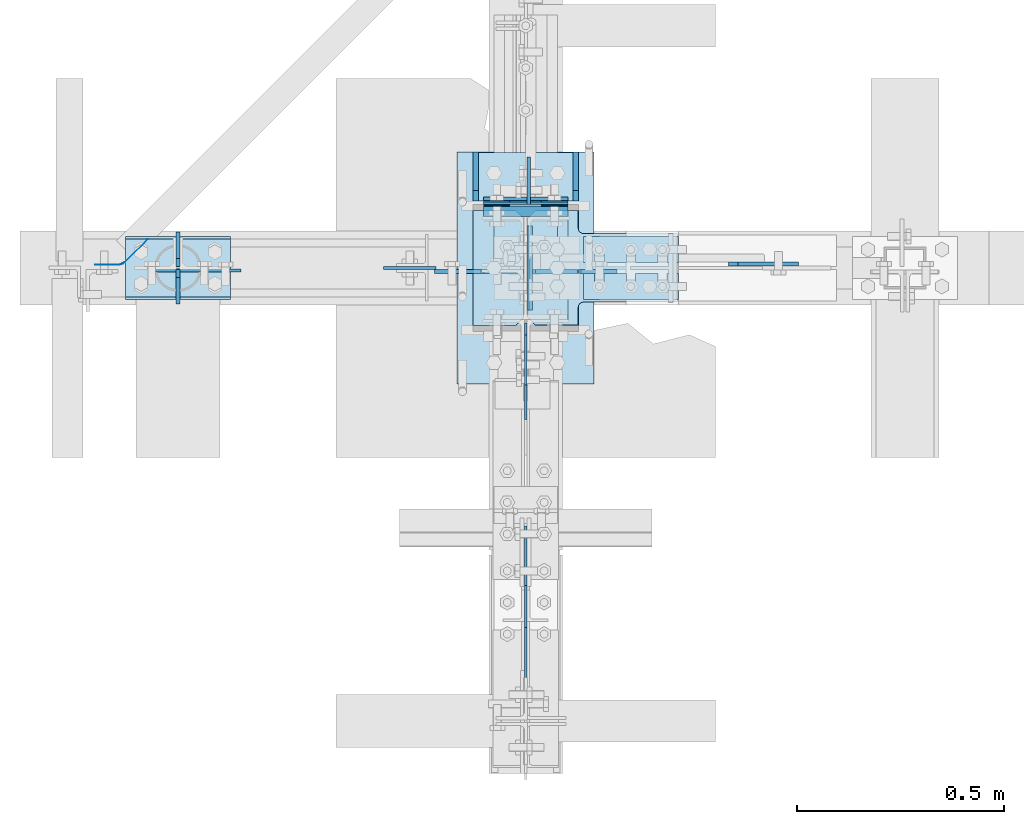
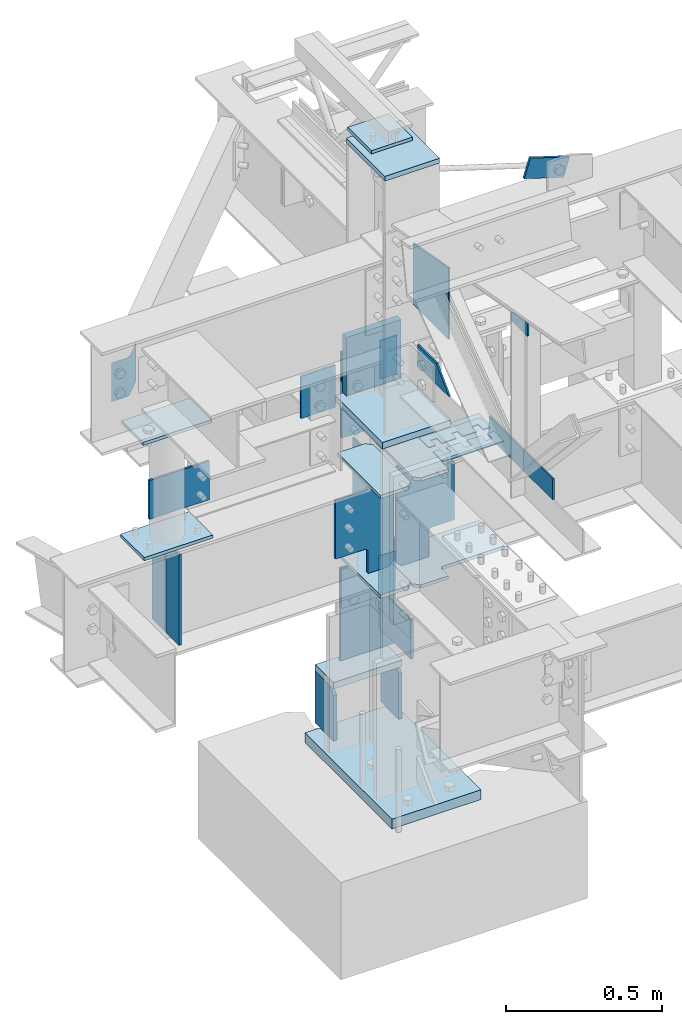
# Not in any storey, part 4 of 7: 38 plates, 16 elements without a shape of their own.
"""IFC2X3 building model written with IfcOpenShell, lengths in inches."""

import ifcopenshell
import ifcopenshell.guid

model = None  # the IFC model being written
_history = None  # IfcOwnerHistory: only IFC2X3 demands one
_inside = {}  # id of a spatial element -> (the spatial element, [elements in it])
_under = {}  # id of a project, library or spatial element -> (it, [spatial elements below it])
_declared = {}  # id of a project -> (the project, [libraries it declares])
_typed = {}  # id of a type object -> (the type object, [elements of that type])
_made_of = {}  # id of a material, layer set ... -> (it, [elements and type objects made of it])


def new_model(schema):
    """Start an empty IFC model of exactly this schema.

    Asked for "IFC4X3", IfcOpenShell would pick the latest addendum, in which some entities
    have other attributes; the version numbers below select the first issue.
    IFC2X3 requires an IfcOwnerHistory on every rooted entity: one is made here for all.
    """
    global model, _history
    if schema == "IFC4X3":
        model = ifcopenshell.file(schema_version=(4, 3, 0, 0))
    else:
        model = ifcopenshell.file(schema=schema)
    _inside.clear()
    _under.clear()
    _declared.clear()
    _typed.clear()
    _made_of.clear()
    _history = None
    if model.schema == "IFC2X3":
        org = make("IfcOrganization", Name="unknown")
        user = make(
            "IfcPersonAndOrganization",
            ThePerson=make("IfcPerson", FamilyName="unknown"),
            TheOrganization=org,
        )
        app = make(
            "IfcApplication",
            ApplicationDeveloper=org,
            Version="unknown",
            ApplicationFullName="unknown",
            ApplicationIdentifier="unknown",
        )
        _history = make(
            "IfcOwnerHistory",
            OwningUser=user,
            OwningApplication=app,
            ChangeAction="ADDED",
            CreationDate=0,
        )
    return model


def make(cls, **values):
    """One entity of the class cls with the attributes given. An attribute that is None is left unset."""
    return model.create_entity(
        cls, **{name: value for name, value in values.items() if value is not None}
    )


def entity(cls, *values):
    """Any entity or typed value of the class cls, its attributes in the order of the schema. None: left unset."""
    e = model.create_entity(cls)
    for i, value in enumerate(values):
        if value is not None:
            e[i] = value
    return e


def rooted(cls, **values):
    """An entity with a GlobalId (a new one), such as an element, a storey or a relation."""
    return make(cls, GlobalId=ifcopenshell.guid.new(), OwnerHistory=_history, **values)


def si_unit(unit_type, name, prefix=None):
    """IfcSIUnit, for example si_unit("LENGTHUNIT", "METRE", prefix="MILLI")."""
    return make("IfcSIUnit", UnitType=unit_type, Prefix=prefix, Name=name)


def converted_unit(unit_type, name, factor, base, dimensions=None, offset=None):
    """IfcConversionBasedUnit, such as the inch: factor (a typed value) times the base unit."""
    return make(
        "IfcConversionBasedUnit"
        if offset is None
        else "IfcConversionBasedUnitWithOffset",
        ConversionOffset=offset,
        Dimensions=None
        if dimensions is None
        else entity("IfcDimensionalExponents", *dimensions),
        UnitType=unit_type,
        Name=name,
        ConversionFactor=make(
            "IfcMeasureWithUnit", ValueComponent=factor, UnitComponent=base
        ),
    )


def assignment(units):
    """IfcUnitAssignment: the units of a project."""
    return None if units is None else make("IfcUnitAssignment", Units=units)


def point(xyz):
    """IfcCartesianPoint."""
    return None if xyz is None else make("IfcCartesianPoint", Coordinates=xyz)


def direction(xyz):
    """IfcDirection."""
    return None if xyz is None else make("IfcDirection", DirectionRatios=xyz)


def frame(location, z_axis=None, x_axis=None):
    """IfcAxis2Placement3D, a coordinate frame: its origin and axes. An axis left out is left unset."""
    return make(
        "IfcAxis2Placement3D",
        Location=point(location),
        Axis=direction(z_axis),
        RefDirection=direction(x_axis),
    )


def origin_with_axes():
    """The frame at (0, 0, 0) with the z axis (0, 0, 1) and the x axis (1, 0, 0) written out."""
    return frame((0.0, 0.0, 0.0), z_axis=(0.0, 0.0, 1.0), x_axis=(1.0, 0.0, 0.0))


def place(relative_to, where):
    """IfcLocalPlacement: puts the frame where relative to a parent placement (None: the world)."""
    return make(
        "IfcLocalPlacement", PlacementRelTo=relative_to, RelativePlacement=where
    )


def context(
    kind, dimensions, precision=None, world=None, true_north=None, identifier=None
):
    """IfcGeometricRepresentationContext, for example the 3D "Model" context."""
    return make(
        "IfcGeometricRepresentationContext",
        ContextIdentifier=identifier,
        ContextType=kind,
        CoordinateSpaceDimension=dimensions,
        Precision=precision,
        WorldCoordinateSystem=world,
        TrueNorth=true_north,
    )


def project(units=None, contexts=None):
    """IfcProject with its units and contexts."""
    return rooted(
        "IfcProject",
        Name="project",
        RepresentationContexts=contexts,
        UnitsInContext=assignment(units),
    )


def spatial(cls, under=None, at=None, **own):
    """A site, building, storey or space (cls), placed at a placement, below another one or the project."""
    s = rooted(cls, ObjectPlacement=at, **own)
    if under is not None:
        _under.setdefault(under.id(), (under, []))[1].append(s)
    return s


def polyline(points):
    """IfcPolyline through the points."""
    return make("IfcPolyline", Points=[point(p) for p in points])


def outline(outer, holes=None, kind="AREA"):
    """IfcArbitraryClosedProfileDef: a profile drawn as a closed curve; with holes, ...WithVoids."""
    if holes is None:
        return make("IfcArbitraryClosedProfileDef", ProfileType=kind, OuterCurve=outer)
    return make(
        "IfcArbitraryProfileDefWithVoids",
        ProfileType=kind,
        OuterCurve=outer,
        InnerCurves=holes,
    )


def extrude(swept, where, along, depth):
    """IfcExtrudedAreaSolid: the profile swept, set in the frame where, extruded along a direction by depth."""
    return make(
        "IfcExtrudedAreaSolid",
        SweptArea=swept,
        Position=where,
        ExtrudedDirection=direction(along),
        Depth=depth,
    )


def shape(context_of_items, identifier, shape_type, items):
    """IfcShapeRepresentation: the items that make up one representation, for example the "Body"."""
    return make(
        "IfcShapeRepresentation",
        ContextOfItems=context_of_items,
        RepresentationIdentifier=identifier,
        RepresentationType=shape_type,
        Items=items,
    )


def source(mapping_origin, context_of_items, identifier, shape_type, items):
    """IfcRepresentationMap: a shape defined once, which mapped items show again and again."""
    return make(
        "IfcRepresentationMap",
        MappingOrigin=mapping_origin,
        MappedRepresentation=shape(context_of_items, identifier, shape_type, items),
    )


def transform(
    local_origin,
    x_axis=None,
    y_axis=None,
    z_axis=None,
    scale=None,
    scale2=None,
    scale3=None,
    uniform=True,
):
    """IfcCartesianTransformationOperator3D, or its non-uniform kind. x_axis, y_axis, z_axis: its Axis1, 2, 3."""
    if uniform:
        return make(
            "IfcCartesianTransformationOperator3D",
            Axis1=direction(x_axis),
            Axis2=direction(y_axis),
            LocalOrigin=point(local_origin),
            Scale=scale,
            Axis3=direction(z_axis),
        )
    return make(
        "IfcCartesianTransformationOperator3DnonUniform",
        Axis1=direction(x_axis),
        Axis2=direction(y_axis),
        LocalOrigin=point(local_origin),
        Scale=scale,
        Axis3=direction(z_axis),
        Scale2=scale2,
        Scale3=scale3,
    )


def mapped(mapping_source, mapping_target):
    """IfcMappedItem: shows the shape of a source again, moved by a transform."""
    return make(
        "IfcMappedItem", MappingSource=mapping_source, MappingTarget=mapping_target
    )


def material(Name=None, Category=None):
    """IfcMaterial."""
    return make("IfcMaterial", Name=Name, Category=Category)


def made_of(thing, what):
    """Note that an element or type object is made of a material, layer set ...; save() writes the relation."""
    if what is not None:
        _made_of.setdefault(what.id(), (what, []))[1].append(thing)
    return thing


def type_object(cls, material=None, **own):
    """A type object (cls), such as IfcWallType, which elements share."""
    return made_of(rooted(cls, **own), material)


def type_shapes(of_type, sources):
    """Give a type object the sources (RepresentationMaps) that its elements show as mapped items."""
    of_type.RepresentationMaps = sources


def element(
    cls,
    number,
    at=None,
    inside=None,
    cuts=None,
    type_object=None,
    material=None,
    context=None,
    identifier="Body",
    shape_type=None,
    held_by="IfcProductDefinitionShape",
    body=None,
    shapes=None,
    **own,
):
    """One element of the class cls, such as IfcWall. Its Tag is "e" and its number.

    at: its placement. inside: the storey or other place that contains it. cuts: it is an
    opening in that element (IfcRelVoidsElement). A single representation is given by context,
    identifier, shape_type and body (its items); several are given by shapes. held_by: the class
    of the entity that holds the representations. save() writes the other relations.
    """
    e = rooted(cls, Tag="e%d" % number, ObjectPlacement=at, **own)
    if body is not None:
        shapes = [shape(context, identifier, shape_type, body)]
    if shapes is not None:
        e.Representation = make(held_by, Representations=shapes)
    if inside is not None:
        _inside.setdefault(inside.id(), (inside, []))[1].append(e)
    if cuts is not None:
        rooted(
            "IfcRelVoidsElement", RelatingBuildingElement=cuts, RelatedOpeningElement=e
        )
    if type_object is not None:
        _typed.setdefault(type_object.id(), (type_object, []))[1].append(e)
    return made_of(e, material)


def aggregate(whole, parts):
    """IfcRelAggregates: a whole, such as a stair, and the parts it consists of."""
    return rooted("IfcRelAggregates", RelatingObject=whole, RelatedObjects=parts)


def save(model, path):
    """Write the relations noted so far, then the file.

    IfcRelAggregates (storeys below a building ...), IfcRelContainedInSpatialStructure (elements
    in a storey), IfcRelDefinesByType, IfcRelAssociatesMaterial and IfcRelDeclares: one each for
    every whole, place, type object, material and project.
    """
    for whole, parts in _under.values():
        aggregate(whole, parts)
    for where, things in _inside.values():
        rooted(
            "IfcRelContainedInSpatialStructure",
            RelatedElements=things,
            RelatingStructure=where,
        )
    for kind, things in _typed.values():
        rooted("IfcRelDefinesByType", RelatedObjects=things, RelatingType=kind)
    for what, things in _made_of.values():
        rooted("IfcRelAssociatesMaterial", RelatedObjects=things, RelatingMaterial=what)
    for by, libraries in _declared.values():
        rooted("IfcRelDeclares", RelatingContext=by, RelatedDefinitions=libraries)
    model.write(path)


model = new_model("IFC2X3")

# Units and contexts
model_context = context("Model", 3, precision=1e-05, world=origin_with_axes())
ifc_project = project(units=[converted_unit("LENGTHUNIT", "INCH", entity("IfcLengthMeasure", 25.4), si_unit("LENGTHUNIT", "METRE", prefix="MILLI"), dimensions=[1, 0, 0, 0, 0, 0, 0]), si_unit("PLANEANGLEUNIT", "RADIAN"), si_unit("MASSUNIT", "GRAM", prefix="KILO"), si_unit("TIMEUNIT", "SECOND"), si_unit("AREAUNIT", "SQUARE_METRE"), si_unit("PRESSUREUNIT", "PASCAL"), si_unit("FORCEUNIT", "NEWTON"), si_unit("THERMODYNAMICTEMPERATUREUNIT", "DEGREE_CELSIUS")], contexts=[model_context])

# Site, building
site_placement = place(None, origin_with_axes())
site = spatial("IfcSite", under=ifc_project, at=site_placement, CompositionType="ELEMENT")
building_placement = place(site_placement, origin_with_axes())
building = spatial("IfcBuilding", under=site, at=building_placement, Name="Building", CompositionType="ELEMENT")

# Assembly, plate
assembly_1_placement = place(building_placement, frame((0.0, 0.0, 97.0), z_axis=(0.0, 0.0, -1.0), x_axis=(0.0, 1.0, 0.0)))
assembly_1 = element("IfcElementAssembly", 1, at=assembly_1_placement, inside=building, Name="M_40", PredefinedType="NOTDEFINED")
ifc_material_1 = material()
plate_type_1 = type_object("IfcPlateType", Name="Plate (0-6x0-6)", PredefinedType="SHEET", material=ifc_material_1)
shared_shape_1 = source(origin_with_axes(), model_context, "Body", "SweptSolid", [
    extrude(outline(polyline([(0.0, -6.0), (-6.0, -6.0), (-6.0, 0.0), (0.0, 0.0), (0.0, -6.0)])), frame((-0.25, 0.0, 0.0), z_axis=(1.0, 0.0, 0.0), x_axis=(0.0, 1.0, 0.0)), (0.0, 0.0, 1.0), 0.5),
])
type_shapes(plate_type_1, [shared_shape_1])
plate_1_placement = place(assembly_1_placement, frame((6.25, -3.0, 2.24999999999999), z_axis=(0.0, -1.0, 0.0), x_axis=(0.0, 0.0, -1.0)))
plate_1 = element("IfcPlate", 2, at=plate_1_placement, type_object=plate_type_1, Name="p15", ObjectType="Member", context=model_context, shape_type="MappedRepresentation", body=[
    mapped(shared_shape_1, transform((0.0, 0.0, 0.0), scale=1.0)),
])
aggregate(assembly_1, [plate_1])

assembly_2_placement = place(building_placement, frame((23.9999999999998, 0.9375, 83.0), z_axis=(0.0, 1.0, 0.0), x_axis=(-0.954479957764932, 0.0, 0.29827505800024)))
assembly_2 = element("IfcElementAssembly", 3, at=assembly_2_placement, inside=building, Name="4-7", PredefinedType="NOTDEFINED")
plate_type_2 = type_object("IfcPlateType", Name="Plate (0-3x0-6)", PredefinedType="SHEET", material=ifc_material_1)
shared_shape_2 = source(origin_with_axes(), model_context, "Body", "SweptSolid", [
    extrude(outline(polyline([(0.0, -3.0), (-6.0, -3.0), (-6.0, 0.0), (0.0, 0.0), (0.0, -3.0)])), frame((-0.1875, 0.0, 0.0), z_axis=(1.0, 0.0, 0.0), x_axis=(0.0, 1.0, 0.0)), (0.0, 0.0, 1.0), 0.375),
])
type_shapes(plate_type_2, [shared_shape_2])
plate_2_placement = place(assembly_2_placement, frame((4.50000040893256, -1.49999996688446, -0.562499999999998), z_axis=(0.0, -1.0, 0.0), x_axis=(0.0, 0.0, -1.0)))
plate_2 = element("IfcPlate", 4, at=plate_2_placement, type_object=plate_type_2, Name="p2", ObjectType="Vertical brace", context=model_context, shape_type="MappedRepresentation", body=[
    mapped(shared_shape_2, transform((0.0, 0.0, 0.0), scale=1.0)),
])
aggregate(assembly_2, [plate_2])

assembly_3_placement = place(building_placement, frame((1.5, 5.86499977111816, 54.75), z_axis=(-1.0, 0.0, 0.0), x_axis=(0.0, -1.0, 0.0)))
assembly_3 = element("IfcElementAssembly", 5, at=assembly_3_placement, inside=building, Name="1-4", PredefinedType="NOTDEFINED")
plate_type_3 = type_object("IfcPlateType", Name="Plate (2 1/2x0-6)", PredefinedType="SHEET", material=ifc_material_1)
shared_shape_3 = source(origin_with_axes(), model_context, "Body", "SweptSolid", [
    extrude(outline(polyline([(0.0, -2.5), (-6.0, -2.5), (-6.0, 0.0), (0.0, 0.0), (0.0, -2.5)])), frame((-0.0625, 0.0, 0.0), z_axis=(1.0, 0.0, 0.0), x_axis=(0.0, 1.0, 0.0)), (0.0, 0.0, 1.0), 0.125),
])
type_shapes(plate_type_3, [shared_shape_3])
plate_3_placement = place(assembly_3_placement, frame((-0.0625, 0.0, 0.0), z_axis=(0.0, 0.0, 1.0), x_axis=(-1.0, 0.0, 0.0)))
plate_3 = element("IfcPlate", 6, at=plate_3_placement, type_object=plate_type_3, Name="p53", ObjectType="Member", context=model_context, shape_type="MappedRepresentation", body=[
    mapped(shared_shape_3, transform((0.0, 0.0, 0.0), scale=1.0)),
])
aggregate(assembly_3, [plate_3])

assembly_4_placement = place(building_placement, frame((-4.0, 5.86499977111816, 54.75), z_axis=(-1.0, 0.0, 0.0), x_axis=(0.0, -1.0, 0.0)))
assembly_4 = element("IfcElementAssembly", 7, at=assembly_4_placement, inside=building, Name="1-4", PredefinedType="NOTDEFINED")
plate_4_placement = place(assembly_4_placement, frame((-0.0625, 0.0, 0.0), z_axis=(0.0, 0.0, 1.0), x_axis=(-1.0, 0.0, 0.0)))
plate_4 = element("IfcPlate", 8, at=plate_4_placement, type_object=plate_type_3, Name="p53", ObjectType="Member", context=model_context, shape_type="MappedRepresentation", body=[
    mapped(shared_shape_3, transform((0.0, 0.0, 0.0), scale=1.0)),
])
aggregate(assembly_4, [plate_4])

assembly_5_placement = place(building_placement, frame((1.5, 6.28000068664551, 21.25), z_axis=(-1.0, 0.0, 0.0), x_axis=(0.0, -1.0, 0.0)))
assembly_5 = element("IfcElementAssembly", 9, at=assembly_5_placement, inside=building, Name="1-4", PredefinedType="NOTDEFINED")
plate_5_placement = place(assembly_5_placement, frame((-0.0625, 0.0, 0.0), z_axis=(0.0, 0.0, 1.0), x_axis=(-1.0, 0.0, 0.0)))
plate_5 = element("IfcPlate", 10, at=plate_5_placement, type_object=plate_type_3, Name="p53", ObjectType="Member", context=model_context, shape_type="MappedRepresentation", body=[
    mapped(shared_shape_3, transform((0.0, 0.0, 0.0), scale=1.0)),
])
aggregate(assembly_5, [plate_5])

assembly_6_placement = place(building_placement, frame((-4.0, 6.28000068664551, 21.25), z_axis=(-1.0, 0.0, 0.0), x_axis=(0.0, -1.0, 0.0)))
assembly_6 = element("IfcElementAssembly", 11, at=assembly_6_placement, inside=building, Name="1-4", PredefinedType="NOTDEFINED")
plate_6_placement = place(assembly_6_placement, frame((-0.0625, 0.0, 0.0), z_axis=(0.0, 0.0, 1.0), x_axis=(-1.0, 0.0, 0.0)))
plate_6 = element("IfcPlate", 12, at=plate_6_placement, type_object=plate_type_3, Name="p53", ObjectType="Member", context=model_context, shape_type="MappedRepresentation", body=[
    mapped(shared_shape_3, transform((0.0, 0.0, 0.0), scale=1.0)),
])
aggregate(assembly_6, [plate_6])

assembly_7_placement = place(building_placement, frame((5.48500061035156, 3.0, 46.0), z_axis=(-1.0, 0.0, 0.0), x_axis=(0.0, 0.0, 1.0)))
assembly_7 = element("IfcElementAssembly", 13, at=assembly_7_placement, inside=building, Name="1-5", PredefinedType="NOTDEFINED")
plate_type_4 = type_object("IfcPlateType", Name="Plate (Complex)", PredefinedType="SHEET", material=ifc_material_1)
shared_shape_4 = source(origin_with_axes(), model_context, "Body", "SweptSolid", [
    extrude(outline(polyline([(-1.25, -1.0625), (-2.5, -1.0625), (-2.5, 0.0), (0.0, 0.0), (0.0, -9.0), (-2.5, -9.0), (-2.5, -7.9375), (-1.25, -7.9375), (-1.25, -7.0625), (-2.5, -7.0625), (-2.5, -4.9375), (-1.25, -4.9375), (-1.25, -4.0625), (-2.5, -4.0625), (-2.5, -1.9375), (-1.25, -1.9375), (-1.25, -1.0625)])), frame((-0.0625, 0.0, 0.0), z_axis=(1.0, 0.0, 0.0), x_axis=(0.0, 1.0, 0.0)), (0.0, 0.0, 1.0), 0.125),
])
type_shapes(plate_type_4, [shared_shape_4])
plate_7_placement = place(assembly_7_placement, frame((0.0624999999999858, 0.0, 0.0), z_axis=(0.0, 0.0, 1.0), x_axis=(1.0, 0.0, 0.0)))
plate_7 = element("IfcPlate", 14, at=plate_7_placement, type_object=plate_type_4, Name="p56", ObjectType="Member", context=model_context, shape_type="MappedRepresentation", body=[
    mapped(shared_shape_4, transform((0.0, 0.0, 0.0), scale=1.0)),
])
aggregate(assembly_7, [plate_7])

assembly_8_placement = place(building_placement, frame((5.48500061035156, -3.0, 46.0), z_axis=(-1.0, 0.0, 0.0), x_axis=(0.0, 0.0, 1.0)))
assembly_8 = element("IfcElementAssembly", 15, at=assembly_8_placement, inside=building, Name="1-5", PredefinedType="NOTDEFINED")
plate_8_placement = place(assembly_8_placement, frame((0.0624999999999858, 0.0, -9.0), z_axis=(0.0, 0.0, -1.0), x_axis=(1.0, 0.0, 0.0)))
plate_8 = element("IfcPlate", 16, at=plate_8_placement, type_object=plate_type_4, Name="p56", ObjectType="Member", context=model_context, shape_type="MappedRepresentation", body=[
    mapped(shared_shape_4, transform((0.0, 0.0, 0.0), scale=1.0)),
])
aggregate(assembly_8, [plate_8])

# Assembly, plates
assembly_9_placement = place(building_placement, frame((0.0, 0.0, -1.5), z_axis=(0.0, -1.0, 0.0), x_axis=(0.0, 0.0, 1.0)))
assembly_9 = element("IfcElementAssembly", 17, at=assembly_9_placement, inside=building, Name="1-1", PredefinedType="NOTDEFINED")
ifc_material_2 = material()
plate_type_5 = type_object("IfcPlateType", Name="Plate (1-10x1-1)", PredefinedType="SHEET", material=ifc_material_2)
shared_shape_5 = source(origin_with_axes(), model_context, "Body", "SweptSolid", [
    extrude(outline(polyline([(6.5, -11.0), (-6.5, -11.0), (-6.5, 11.0), (6.5, 11.0), (6.5, -11.0)])), frame((-0.75, 0.0, 0.0), z_axis=(1.0, 0.0, 0.0), x_axis=(0.0, 1.0, 0.0)), (0.0, 0.0, 1.0), 1.5),
])
type_shapes(plate_type_5, [shared_shape_5])
plate_9_placement = place(assembly_9_placement, frame((0.75, 0.0, 0.0), z_axis=(0.0, 0.0, -1.0), x_axis=(1.0, 0.0, 0.0)))
plate_9 = element("IfcPlate", 18, at=plate_9_placement, type_object=plate_type_5, Name="p33", ObjectType="Column", context=model_context, shape_type="MappedRepresentation", body=[
    mapped(shared_shape_5, transform((0.0, 0.0, 0.0), scale=1.0)),
])
plate_type_6 = type_object("IfcPlateType", Name="Plate (1-2 1/4x0-8)", PredefinedType="SHEET", material=ifc_material_1)
shared_shape_6 = source(origin_with_axes(), model_context, "Body", "SweptSolid", [
    extrude(outline(polyline([(4.0, -14.25), (-4.0, -14.25), (-4.0, 0.0), (4.0, 0.0), (4.0, -14.25)])), frame((-0.1875, 0.0, 0.0), z_axis=(1.0, 0.0, 0.0), x_axis=(0.0, 1.0, 0.0)), (0.0, 0.0, 1.0), 0.375),
])
type_shapes(plate_type_6, [shared_shape_6])
plate_10_placement = place(assembly_9_placement, frame((14.5, 0.0, -6.54250001907349), z_axis=(-1.0, 0.0, 0.0), x_axis=(0.0, 0.0, -1.0)))
plate_10 = element("IfcPlate", 19, at=plate_10_placement, type_object=plate_type_6, Name="p39", ObjectType="Column", context=model_context, shape_type="MappedRepresentation", body=[
    mapped(shared_shape_6, transform((0.0, 0.0, 0.0), scale=1.0)),
])
plate_type_7 = type_object("IfcPlateType", Name="Plate (0-8x0-6)", PredefinedType="SHEET", material=ifc_material_1)
shared_shape_7 = source(origin_with_axes(), model_context, "Body", "SweptSolid", [
    extrude(outline(polyline([(0.0, -8.0), (-6.0, -8.0), (-6.0, 0.0), (0.0, 0.0), (0.0, -8.0)])), frame((-0.1875, 0.0, 0.0), z_axis=(1.0, 0.0, 0.0), x_axis=(0.0, 1.0, 0.0)), (0.0, 0.0, 1.0), 0.375),
])
type_shapes(plate_type_7, [shared_shape_7])
plate_11_placement = place(assembly_9_placement, frame((25.5, -0.462500005960464, 4.0), z_axis=(0.0, 0.0, 1.0), x_axis=(0.0, -1.0, 0.0)))
plate_11 = element("IfcPlate", 20, at=plate_11_placement, type_object=plate_type_7, Name="p40", ObjectType="Column", context=model_context, shape_type="MappedRepresentation", body=[
    mapped(shared_shape_7, transform((0.0, 0.0, 0.0), scale=1.0)),
])
plate_type_8 = type_object("IfcPlateType", Name="Plate (Complex)", PredefinedType="SHEET", material=ifc_material_1)
shared_shape_8 = source(origin_with_axes(), model_context, "Body", "SweptSolid", [
    extrude(outline(polyline([(0.0, -8.0), (-3.625, -8.0), (-4.625, -7.0), (-4.625, 0.0), (0.0, 0.0), (0.0, -8.0)])), frame((-0.25, 0.0, 0.0), z_axis=(1.0, 0.0, 0.0), x_axis=(0.0, 1.0, 0.0)), (0.0, 0.0, 1.0), 0.5),
])
type_shapes(plate_type_8, [shared_shape_8])
plate_12_placement = place(assembly_9_placement, frame((2.5, 4.75, -10.9999995231628), z_axis=(-1.0, 0.0, 0.0), x_axis=(0.0, 1.0, 0.0)))
plate_12 = element("IfcPlate", 21, at=plate_12_placement, type_object=plate_type_8, Name="p21", ObjectType="Column", context=model_context, shape_type="MappedRepresentation", body=[
    mapped(shared_shape_8, transform((0.0, 0.0, 0.0), scale=1.0)),
])
plate_13_placement = place(assembly_9_placement, frame((2.5, -4.75, -10.9999995231628), z_axis=(-1.0, 0.0, 0.0), x_axis=(0.0, 1.0, 0.0)))
plate_13 = element("IfcPlate", 22, at=plate_13_placement, type_object=plate_type_8, Name="p21", ObjectType="Column", context=model_context, shape_type="MappedRepresentation", body=[
    mapped(shared_shape_8, transform((0.0, 0.0, 0.0), scale=1.0)),
])
plate_type_9 = type_object("IfcPlateType", Name="Plate (0-10x4 5/8)", PredefinedType="SHEET", material=ifc_material_1)
shared_shape_9 = source(origin_with_axes(), model_context, "Body", "SweptSolid", [
    extrude(outline(polyline([(0.0, -10.0), (-4.625, -10.0), (-4.625, 0.0), (0.0, 0.0), (0.0, -10.0)])), frame((-0.5, 0.0, 0.0), z_axis=(1.0, 0.0, 0.0), x_axis=(0.0, 1.0, 0.0)), (0.0, 0.0, 1.0), 1.0),
])
type_shapes(plate_type_9, [shared_shape_9])
plate_14_placement = place(assembly_9_placement, frame((11.0, -5.0, -6.35500001907349), z_axis=(0.0, -1.0, 0.0), x_axis=(1.0, 0.0, 0.0)))
plate_14 = element("IfcPlate", 23, at=plate_14_placement, type_object=plate_type_9, Name="p36", ObjectType="Column", context=model_context, shape_type="MappedRepresentation", body=[
    mapped(shared_shape_9, transform((0.0, 0.0, 0.0), scale=1.0)),
])
aggregate(assembly_9, [plate_9, plate_10, plate_11, plate_12, plate_14, plate_13])

assembly_10_placement = place(building_placement, frame((0.0, 0.0, 21.0), z_axis=(0.0, -1.0, 0.0), x_axis=(0.0, 0.0, 1.0)))
assembly_10 = element("IfcElementAssembly", 24, at=assembly_10_placement, inside=building, Name="1-2", PredefinedType="NOTDEFINED")
plate_type_10 = type_object("IfcPlateType", Name="Plate (0-8x0-3)", PredefinedType="SHEET", material=ifc_material_1)
shared_shape_10 = source(origin_with_axes(), model_context, "Body", "SweptSolid", [
    extrude(outline(polyline([(0.0, -8.0), (-3.0, -8.0), (-3.0, 0.0), (0.0, 0.0), (0.0, -8.0)])), frame((-0.0625, 0.0, 0.0), z_axis=(1.0, 0.0, 0.0), x_axis=(0.0, 1.0, 0.0)), (0.0, 0.0, 1.0), 0.125),
])
type_shapes(plate_type_10, [shared_shape_10])
plate_15_placement = place(assembly_10_placement, frame((3.25, -0.234999999403954, 4.0), z_axis=(0.0, 0.0, 1.0), x_axis=(0.0, -1.0, 0.0)))
plate_15 = element("IfcPlate", 25, at=plate_15_placement, type_object=plate_type_10, Name="p44", ObjectType="Column", context=model_context, shape_type="MappedRepresentation", body=[
    mapped(shared_shape_10, transform((0.0, 0.0, 0.0), scale=1.0)),
])
plate_type_11 = type_object("IfcPlateType", Name="Plate (1-1 1/4x0-8)", PredefinedType="SHEET", material=ifc_material_1)
shared_shape_11 = source(origin_with_axes(), model_context, "Body", "SweptSolid", [
    extrude(outline(polyline([(4.0, -13.25), (-4.0, -13.25), (-4.0, 0.0), (4.0, 0.0), (4.0, -13.25)])), frame((-0.1875, 0.0, 0.0), z_axis=(1.0, 0.0, 0.0), x_axis=(0.0, 1.0, 0.0)), (0.0, 0.0, 1.0), 0.375),
])
type_shapes(plate_type_11, [shared_shape_11])
plate_16_placement = place(assembly_10_placement, frame((26.5, 0.0, -6.21750020980835), z_axis=(-1.0, 0.0, 0.0), x_axis=(0.0, 0.0, -1.0)))
plate_16 = element("IfcPlate", 26, at=plate_16_placement, type_object=plate_type_11, Name="p47", ObjectType="Column", context=model_context, shape_type="MappedRepresentation", body=[
    mapped(shared_shape_11, transform((0.0, 0.0, 0.0), scale=1.0)),
])
plate_type_12 = type_object("IfcPlateType", Name="Plate (Complex)", PredefinedType="SHEET", material=ifc_material_1)
shared_shape_12 = source(origin_with_axes(), model_context, "Body", "SweptSolid", [
    extrude(outline(polyline([(0.0, -4.75), (-2.125, -4.75), (-2.316342, -4.78806), (-2.478553, -4.896447), (-2.58694, -5.058658), (-2.625, -5.25), (-2.625, -8.5), (-11.625, -8.5), (-11.625, -5.25), (-11.66306, -5.058658), (-11.771447, -4.896447), (-11.933658, -4.78806), (-12.125, -4.75), (-16.0, -4.75), (-16.0, -0.75), (-15.25, 0.0), (-0.75, 0.0), (0.0, -0.75), (0.0, -4.75)])), frame((-0.1875, 0.0, 0.0), z_axis=(1.0, 0.0, 0.0), x_axis=(0.0, 1.0, 0.0)), (0.0, 0.0, 1.0), 0.375),
])
type_shapes(plate_type_12, [shared_shape_12])
plate_17_placement = place(assembly_10_placement, frame((25.125, -0.172499999403954, 0.33500000834465), z_axis=(0.0, 1.0, 0.0), x_axis=(0.0, 0.0, 1.0)))
plate_17 = element("IfcPlate", 27, at=plate_17_placement, type_object=plate_type_12, Name="p45", ObjectType="Column", context=model_context, shape_type="MappedRepresentation", body=[
    mapped(shared_shape_12, transform((0.0, 0.0, 0.0), scale=1.0)),
])
plate_type_13 = type_object("IfcPlateType", Name="Plate (1-0x0-10)", PredefinedType="SHEET", material=ifc_material_1)
shared_shape_13 = source(origin_with_axes(), model_context, "Body", "SweptSolid", [
    extrude(outline(polyline([(3.98, -6.095), (-6.02, -6.095), (-6.02, 5.905), (3.98, 5.905), (3.98, -6.095)])), frame((-0.5, 0.0, 0.0), z_axis=(1.0, 0.0, 0.0), x_axis=(0.0, 1.0, 0.0)), (0.0, 0.0, 1.0), 1.0),
])
type_shapes(plate_type_13, [shared_shape_13])
plate_18_placement = place(assembly_10_placement, frame((33.0, 1.01999998092651, -0.0949997901916504), z_axis=(0.0, 0.0, -1.0), x_axis=(-1.0, 0.0, 0.0)))
plate_18 = element("IfcPlate", 28, at=plate_18_placement, type_object=plate_type_13, Name="p3", ObjectType="Column", context=model_context, shape_type="MappedRepresentation", body=[
    mapped(shared_shape_13, transform((0.0, 0.0, 0.0), scale=1.0)),
])
plate_type_14 = type_object("IfcPlateType", Name="Plate (Complex)", PredefinedType="SHEET", material=ifc_material_1)
shared_shape_14 = source(origin_with_axes(), model_context, "Body", "SweptSolid", [
    extrude(outline(polyline([(0.0, -3.75), (-1.5, -3.75), (-1.691342, -3.78806), (-1.853553, -3.896447), (-1.96194, -4.058658), (-2.0, -4.25), (-2.0, -8.5), (-11.0, -8.5), (-11.0, -4.25), (-11.03806, -4.058658), (-11.146447, -3.896447), (-11.308658, -3.78806), (-11.5, -3.75), (-14.875, -3.75), (-14.875, -0.75), (-14.125, 0.0), (-0.75, 0.0), (0.0, -0.75), (0.0, -3.75)])), frame((-0.1875, 0.0, 0.0), z_axis=(1.0, 0.0, 0.0), x_axis=(0.0, 1.0, 0.0)), (0.0, 0.0, 1.0), 0.375),
])
type_shapes(plate_type_14, [shared_shape_14])
plate_19_placement = place(assembly_10_placement, frame((24.5, 0.172500014305115, 0.334998160600662), z_axis=(0.0, -1.0, 0.0), x_axis=(0.0, 0.0, -1.0)))
plate_19 = element("IfcPlate", 29, at=plate_19_placement, type_object=plate_type_14, Name="p46", ObjectType="Column", context=model_context, shape_type="MappedRepresentation", body=[
    mapped(shared_shape_14, transform((0.0, 0.0, 0.0), scale=1.0)),
])
plate_type_15 = type_object("IfcPlateType", Name="Plate (Complex)", PredefinedType="SHEET", material=ifc_material_1)
shared_shape_15 = source(origin_with_axes(), model_context, "Body", "SweptSolid", [
    extrude(outline(polyline([(5.3925, -4.8125), (3.705, -4.8125), (3.513659, -4.85056), (3.351447, -4.958947), (3.243061, -5.121158), (3.205, -5.3125), (3.205, -14.25), (-3.295, -14.25), (-3.295, -5.3125), (-3.33306, -5.121158), (-3.441446, -4.958947), (-3.603658, -4.85056), (-3.795, -4.8125), (-5.4825, -4.8125), (-5.4825, -0.75), (-4.7325, 0.0), (4.6425, 0.0), (5.3925, -0.75), (5.3925, -4.8125)])), frame((-0.25, 0.0, 0.0), z_axis=(1.0, 0.0, 0.0), x_axis=(0.0, 1.0, 0.0)), (0.0, 0.0, 1.0), 0.5),
])
type_shapes(plate_type_15, [shared_shape_15])
plate_20_placement = place(assembly_10_placement, frame((8.875, -0.172499999403954, -0.0625000184680626), z_axis=(0.0, 1.0, 0.0), x_axis=(1.0, 0.0, 0.0)))
plate_20 = element("IfcPlate", 30, at=plate_20_placement, type_object=plate_type_15, Name="p17", ObjectType="Column", context=model_context, shape_type="MappedRepresentation", body=[
    mapped(shared_shape_15, transform((0.0, 0.0, 0.0), scale=1.0)),
])
plate_21_placement = place(assembly_10_placement, frame((25.375, -0.172499999403953, -0.0625000184680629), z_axis=(0.0, 1.0, 0.0), x_axis=(1.0, 0.0, 0.0)))
plate_21 = element("IfcPlate", 31, at=plate_21_placement, type_object=plate_type_15, Name="p17", ObjectType="Column", context=model_context, shape_type="MappedRepresentation", body=[
    mapped(shared_shape_15, transform((0.0, 0.0, 0.0), scale=1.0)),
])
plate_type_16 = type_object("IfcPlateType", Name="Plate (0-8x0-6)", PredefinedType="SHEET", material=ifc_material_1)
shared_shape_16 = source(origin_with_axes(), model_context, "Body", "SweptSolid", [
    extrude(outline(polyline([(0.0, -8.0), (-6.0, -8.0), (-6.0, 0.0), (0.0, 0.0), (0.0, -8.0)])), frame((-0.125, 0.0, 0.0), z_axis=(1.0, 0.0, 0.0), x_axis=(0.0, 1.0, 0.0)), (0.0, 0.0, 1.0), 0.25),
])
type_shapes(plate_type_16, [shared_shape_16])
plate_22_placement = place(assembly_10_placement, frame((6.25, -4.0, -6.15500020980835), z_axis=(0.0, -1.0, 0.0), x_axis=(0.0, 0.0, -1.0)))
plate_22 = element("IfcPlate", 32, at=plate_22_placement, type_object=plate_type_16, Name="p43", ObjectType="Column", context=model_context, shape_type="MappedRepresentation", body=[
    mapped(shared_shape_16, transform((0.0, 0.0, 0.0), scale=1.0)),
])
plate_type_17 = type_object("IfcPlateType", Name="Plate (4 1/2x0-11)", PredefinedType="SHEET", material=ifc_material_1)
shared_shape_17 = source(origin_with_axes(), model_context, "Body", "SweptSolid", [
    extrude(outline(polyline([(0.0, -4.5), (-11.0, -4.5), (-11.0, 0.0), (0.0, 0.0), (0.0, -4.5)])), frame((-0.15625, 0.0, 0.0), z_axis=(1.0, 0.0, 0.0), x_axis=(0.0, 1.0, 0.0)), (0.0, 0.0, 1.0), 0.3125),
])
type_shapes(plate_type_17, [shared_shape_17])
plate_23_placement = place(assembly_10_placement, frame((22.5, -0.30375000834465, -6.03000020980835), z_axis=(0.0, 0.0, 1.0), x_axis=(0.0, -1.0, 0.0)))
plate_23 = element("IfcPlate", 33, at=plate_23_placement, type_object=plate_type_17, Name="p52", ObjectType="Column", context=model_context, shape_type="MappedRepresentation", body=[
    mapped(shared_shape_17, transform((0.0, 0.0, 0.0), scale=1.0)),
])
plate_type_18 = type_object("IfcPlateType", Name="Plate (Complex)", PredefinedType="SHEET", material=ifc_material_1)
shared_shape_18 = source(origin_with_axes(), model_context, "Body", "SweptSolid", [
    extrude(outline(polyline([(5.4375, -4.8125), (-5.4375, -4.8125), (-5.4375, -0.75), (-4.6875, 0.0), (4.6875, 0.0), (5.4375, -0.75), (5.4375, -4.8125)])), frame((-0.25, 0.0, 0.0), z_axis=(1.0, 0.0, 0.0), x_axis=(0.0, 1.0, 0.0)), (0.0, 0.0, 1.0), 0.5),
])
type_shapes(plate_type_18, [shared_shape_18])
plate_24_placement = place(assembly_10_placement, frame((24.75, 0.172500014305114, 1.8468062926954e-08), z_axis=(0.0, -1.0, 0.0), x_axis=(1.0, 0.0, 0.0)))
plate_24 = element("IfcPlate", 34, at=plate_24_placement, type_object=plate_type_18, Name="p18", ObjectType="Column", context=model_context, shape_type="MappedRepresentation", body=[
    mapped(shared_shape_18, transform((0.0, 0.0, 0.0), scale=1.0)),
])
plate_25_placement = place(assembly_10_placement, frame((9.375, 0.172500014305114, 1.8468062926954e-08), z_axis=(0.0, -1.0, 0.0), x_axis=(1.0, 0.0, 0.0)))
plate_25 = element("IfcPlate", 35, at=plate_25_placement, type_object=plate_type_18, Name="p18", ObjectType="Column", context=model_context, shape_type="MappedRepresentation", body=[
    mapped(shared_shape_18, transform((0.0, 0.0, 0.0), scale=1.0)),
])
aggregate(assembly_10, [plate_15, plate_16, plate_17, plate_18, plate_19, plate_20, plate_22, plate_23, plate_24, plate_25, plate_21])

assembly_11_placement = place(building_placement, frame((0.0, 0.0, 54.5), z_axis=(0.0, -1.0, 0.0), x_axis=(0.0, 0.0, 1.0)))
assembly_11 = element("IfcElementAssembly", 36, at=assembly_11_placement, inside=building, Name="1-3", PredefinedType="NOTDEFINED")
plate_type_19 = type_object("IfcPlateType", Name="Plate (9 3/4x0-8)", PredefinedType="SHEET", material=ifc_material_2)
shared_shape_19 = source(origin_with_axes(), model_context, "Body", "SweptSolid", [
    extrude(outline(polyline([(4.0, -4.875), (-4.0, -4.875), (-4.0, 4.875), (4.0, 4.875), (4.0, -4.875)])), frame((-0.375, 0.0, 0.0), z_axis=(1.0, 0.0, 0.0), x_axis=(0.0, 1.0, 0.0)), (0.0, 0.0, 1.0), 0.75),
])
type_shapes(plate_type_19, [shared_shape_19])
plate_26_placement = place(assembly_11_placement, frame((39.625, 0.0, 0.0), z_axis=(0.0, 0.0, -1.0), x_axis=(-1.0, 0.0, 0.0)))
plate_26 = element("IfcPlate", 37, at=plate_26_placement, type_object=plate_type_19, Name="p26", ObjectType="Column", context=model_context, shape_type="MappedRepresentation", body=[
    mapped(shared_shape_19, transform((0.0, 0.0, 0.0), scale=1.0)),
])
plate_type_20 = type_object("IfcPlateType", Name="Plate (0-9x0-8)", PredefinedType="SHEET", material=ifc_material_1)
shared_shape_20 = source(origin_with_axes(), model_context, "Body", "SweptSolid", [
    extrude(outline(polyline([(4.0, -9.0), (-4.0, -9.0), (-4.0, 0.0), (4.0, 0.0), (4.0, -9.0)])), frame((-0.5, 0.0, 0.0), z_axis=(1.0, 0.0, 0.0), x_axis=(0.0, 1.0, 0.0)), (0.0, 0.0, 1.0), 1.0),
])
type_shapes(plate_type_20, [shared_shape_20])
plate_27_placement = place(assembly_11_placement, frame((0.236220479011536, 0.0, -5.36499977111816), z_axis=(-1.0, 0.0, 0.0), x_axis=(0.0, 0.0, -1.0)))
plate_27 = element("IfcPlate", 38, at=plate_27_placement, type_object=plate_type_20, Name="p22", ObjectType="Column", context=model_context, shape_type="MappedRepresentation", body=[
    mapped(shared_shape_20, transform((0.0, 0.0, 0.0), scale=1.0)),
])
aggregate(assembly_11, [plate_26, plate_27])

assembly_12_placement = place(building_placement, frame((0.0, 0.0, 46.0), z_axis=(0.0, 0.0, 1.0), x_axis=(-1.0, 0.0, 0.0)))
assembly_12 = element("IfcElementAssembly", 39, at=assembly_12_placement, inside=building, Name="2-4", PredefinedType="NOTDEFINED")
plate_type_21 = type_object("IfcPlateType", Name="Plate (Complex)", PredefinedType="SHEET", material=ifc_material_1)
shared_shape_21 = source(origin_with_axes(), model_context, "Body", "SweptSolid", [
    extrude(outline(polyline([(0.0, -14.0), (-3.25, -14.0), (-3.25, 0.0), (-0.75, 0.0), (0.0, -0.75), (0.0, -14.0)])), frame((-0.1875, 0.0, 0.0), z_axis=(1.0, 0.0, 0.0), x_axis=(0.0, 1.0, 0.0)), (0.0, 0.0, 1.0), 0.375),
])
type_shapes(plate_type_21, [shared_shape_21])
plate_28_placement = place(assembly_12_placement, frame((33.0, 0.14750000834465, -0.492500007152557), z_axis=(0.0, 0.0, 1.0), x_axis=(-1.0, 0.0, 0.0)))
plate_28 = element("IfcPlate", 40, at=plate_28_placement, type_object=plate_type_21, Name="p4", ObjectType="Beam", context=model_context, shape_type="MappedRepresentation", body=[
    mapped(shared_shape_21, transform((0.0, 0.0, 0.0), scale=1.0)),
])
plate_29_placement = place(assembly_12_placement, frame((33.0, -0.14750000834465, -0.492500007152557), z_axis=(0.0, 0.0, 1.0), x_axis=(1.0, 0.0, 0.0)))
plate_29 = element("IfcPlate", 41, at=plate_29_placement, type_object=plate_type_21, Name="p4", ObjectType="Beam", context=model_context, shape_type="MappedRepresentation", body=[
    mapped(shared_shape_21, transform((0.0, 0.0, 0.0), scale=1.0)),
])
aggregate(assembly_12, [plate_28, plate_29])

assembly_13_placement = place(building_placement, frame((-33.0, 0.0, 46.0), z_axis=(-1.0, 0.0, 0.0), x_axis=(0.0, 0.0, 1.0)))
assembly_13 = element("IfcElementAssembly", 42, at=assembly_13_placement, inside=building, Name="4-2", PredefinedType="NOTDEFINED")
plate_type_22 = type_object("IfcPlateType", Name="Plate (0-10x0-6)", PredefinedType="SHEET", material=ifc_material_1)
shared_shape_22 = source(origin_with_axes(), model_context, "Body", "SweptSolid", [
    extrude(outline(polyline([(3.0, -5.25), (-3.0, -5.25), (-3.0, 4.75), (3.0, 4.75), (3.0, -5.25)])), frame((-0.25, 0.0, 0.0), z_axis=(1.0, 0.0, 0.0), x_axis=(0.0, 1.0, 0.0)), (0.0, 0.0, 1.0), 0.5),
])
type_shapes(plate_type_22, [shared_shape_22])
plate_30_placement = place(assembly_13_placement, frame((0.25, 0.0, -0.25), z_axis=(0.0, 0.0, -1.0), x_axis=(1.0, 0.0, 0.0)))
plate_30 = element("IfcPlate", 43, at=plate_30_placement, type_object=plate_type_22, Name="p20", ObjectType="Column", context=model_context, shape_type="MappedRepresentation", body=[
    mapped(shared_shape_22, transform((0.0, 0.0, 0.0), scale=1.0)),
])
plate_type_23 = type_object("IfcPlateType", Name="Plate (0-10x5 1/2)", PredefinedType="SHEET", material=ifc_material_1)
shared_shape_23 = source(origin_with_axes(), model_context, "Body", "SweptSolid", [
    extrude(outline(polyline([(2.75, -5.0), (-2.75, -5.0), (-2.75, 5.0), (2.75, 5.0), (2.75, -5.0)])), frame((-0.25, 0.0, 0.0), z_axis=(1.0, 0.0, 0.0), x_axis=(0.0, 1.0, 0.0)), (0.0, 0.0, 1.0), 0.5),
])
type_shapes(plate_type_23, [shared_shape_23])
plate_31_placement = place(assembly_13_placement, frame((17.875, 0.0, 0.0), z_axis=(0.0, 0.0, -1.0), x_axis=(-1.0, 0.0, 0.0)))
plate_31 = element("IfcPlate", 44, at=plate_31_placement, type_object=plate_type_23, Name="p13", ObjectType="Column", context=model_context, shape_type="MappedRepresentation", body=[
    mapped(shared_shape_23, transform((0.0, 0.0, 0.0), scale=1.0)),
])
plate_type_24 = type_object("IfcPlateType", Name="Plate (8 3/4x0-6)", PredefinedType="SHEET", material=ifc_material_1)
shared_shape_24 = source(origin_with_axes(), model_context, "Body", "SweptSolid", [
    extrude(outline(polyline([(0.0, -8.75), (-6.0, -8.75), (-6.0, 0.0), (0.0, 0.0), (0.0, -8.75)])), frame((-0.15625, 0.0, 0.0), z_axis=(1.0, 0.0, 0.0), x_axis=(0.0, 1.0, 0.0)), (0.0, 0.0, 1.0), 0.3125),
])
type_shapes(plate_type_24, [shared_shape_24])
plate_32_placement = place(assembly_13_placement, frame((10.0, -0.24125000089407, 2.75), z_axis=(0.0, 0.0, 1.0), x_axis=(0.0, -1.0, 0.0)))
plate_32 = element("IfcPlate", 45, at=plate_32_placement, type_object=plate_type_24, Name="p11", ObjectType="Column", context=model_context, shape_type="MappedRepresentation", body=[
    mapped(shared_shape_24, transform((0.0, 0.0, 0.0), scale=1.0)),
])
aggregate(assembly_13, [plate_30, plate_31, plate_32])

# Assembly, plate
assembly_14_placement = place(building_placement, frame((-38.0, 0.0, 77.0), z_axis=(0.0, 0.0, 1.0), x_axis=(0.707106765732237, 0.707106796640858, 0.0)))
assembly_14 = element("IfcElementAssembly", 46, at=assembly_14_placement, inside=building, Name="3-12", PredefinedType="NOTDEFINED")
plate_type_25 = type_object("IfcPlateType", Name="BPL3/8x6-1/2", PredefinedType="USERDEFINED")
shared_shape_25 = source(origin_with_axes(), model_context, "Body", "SweptSolid", [
    extrude(entity("IfcCenterLineProfileDef", "AREA", None, entity("IfcPolyline", [entity("IfcCartesianPoint", [-3.5, 0.1875]), entity("IfcCartesianPoint", [-0.38832, 0.1875]), entity("IfcCartesianPoint", [-0.19421, 0.2131]), entity("IfcCartesianPoint", [-0.01333, 0.288]), entity("IfcCartesianPoint", [0.142, 0.4072]), entity("IfcCartesianPoint", [1.733, 1.9982])]), 0.375), frame((0.0, 0.0, 0.0), z_axis=(1.0, 0.0, 0.0), x_axis=(0.0, 1.0, 0.0)), (0.0, 0.0, 1.0), 6.0),
])
type_shapes(plate_type_25, [shared_shape_25])
plate_33_placement = place(assembly_14_placement, frame((-0.0454999499840696, 0.232999995350838, -1.5), z_axis=(0.0, 1.0, 0.0), x_axis=(0.0, 0.0, -1.0)))
plate_33 = element("IfcPlate", 47, at=plate_33_placement, type_object=plate_type_25, Name="bp6", ObjectType="Beam", context=model_context, shape_type="MappedRepresentation", body=[
    mapped(shared_shape_25, transform((0.0, 0.0, 0.0), scale=1.0)),
])
aggregate(assembly_14, [plate_33])

assembly_15_placement = place(building_placement, frame((0.0, 0.0, 80.0), z_axis=(0.0, 0.0, 1.0), x_axis=(-1.0, 0.0, 0.0)))
assembly_15 = element("IfcElementAssembly", 48, at=assembly_15_placement, inside=building, Name="2-7", PredefinedType="NOTDEFINED")
plate_type_26 = type_object("IfcPlateType", Name="Plate (6 1/2x0-5)", PredefinedType="SHEET", material=ifc_material_1)
shared_shape_26 = source(origin_with_axes(), model_context, "Body", "SweptSolid", [
    extrude(outline(polyline([(0.0, -6.5), (-5.0, -6.5), (-5.0, 0.0), (0.0, 0.0), (0.0, -6.5)])), frame((-0.15625, 0.0, 0.0), z_axis=(1.0, 0.0, 0.0), x_axis=(0.0, 1.0, 0.0)), (0.0, 0.0, 1.0), 0.3125),
])
type_shapes(plate_type_26, [shared_shape_26])
plate_34_placement = place(assembly_15_placement, frame((13.5, 0.0, -15.8800010681152), z_axis=(0.0, 0.0, 1.0), x_axis=(0.0, -1.0, 0.0)))
plate_34 = element("IfcPlate", 49, at=plate_34_placement, type_object=plate_type_26, Name="p9", ObjectType="Beam", context=model_context, shape_type="MappedRepresentation", body=[
    mapped(shared_shape_26, transform((0.0, 0.0, 0.0), scale=1.0)),
])
aggregate(assembly_15, [plate_34])

# Assembly, plates
assembly_16_placement = place(building_placement, frame((0.0, -47.9999999999999, 94.0), z_axis=(0.0, 0.17437043319647, 0.984680126755321), x_axis=(0.0, 0.98468012675532, -0.17437043319647)))
assembly_16 = element("IfcElementAssembly", 50, at=assembly_16_placement, inside=building, Name="4-8", PredefinedType="NOTDEFINED")
plate_type_27 = type_object("IfcPlateType", Name="Plate (Complex)", PredefinedType="SHEET", material=ifc_material_1)
shared_shape_27 = source(origin_with_axes(), model_context, "Body", "SweptSolid", [
    extrude(outline(polyline([(0.0, -4.75), (-3.25, -8.0), (-3.25, 0.0), (0.0, 0.0), (0.0, -4.75)])), frame((-0.125, 0.0, 0.0), z_axis=(1.0, 0.0, 0.0), x_axis=(0.0, 1.0, 0.0)), (0.0, 0.0, 1.0), 0.25),
])
type_shapes(plate_type_27, [shared_shape_27])
plate_35_placement = place(assembly_16_placement, frame((45.4978375101134, -0.00999999791383743, -18.2130441975408), z_axis=(0.98468012675532, 0.0, 0.17437043319647), x_axis=(0.0, 1.0, 0.0)))
plate_35 = element("IfcPlate", 51, at=plate_35_placement, type_object=plate_type_27, Name="p50", ObjectType="Beam", context=model_context, shape_type="MappedRepresentation", body=[
    mapped(shared_shape_27, transform((0.0, 0.0, 0.0), scale=1.0)),
])
plate_type_28 = type_object("IfcPlateType", Name="Plate (Complex)", PredefinedType="SHEET", material=ifc_material_1)
shared_shape_28 = source(origin_with_axes(), model_context, "Body", "SweptSolid", [
    extrude(outline(polyline([(6e-06, -4.000027), (-2.0, -3.999993), (-2.0, 0.0), (-0.708332, 0.0), (6e-06, -4.000027)])), frame((-0.125, 0.0, 0.0), z_axis=(1.0, 0.0, 0.0), x_axis=(0.0, 1.0, 0.0)), (0.0, 0.0, 1.0), 0.25),
])
type_shapes(plate_type_28, [shared_shape_28])
plate_36_placement = place(assembly_16_placement, frame((18.5967003567752, 0.0, -2.58001890383456), z_axis=(0.98468012675532, 0.0, 0.17437043319647), x_axis=(0.0, 1.0, 0.0)))
plate_36 = element("IfcPlate", 52, at=plate_36_placement, type_object=plate_type_28, Name="p60", ObjectType="Beam", context=model_context, shape_type="MappedRepresentation", body=[
    mapped(shared_shape_28, transform((0.0, 0.0, 0.0), scale=1.0)),
])
plate_type_29 = type_object("IfcPlateType", Name="Plate (1-4x3 1/4)", PredefinedType="SHEET", material=ifc_material_1)
shared_shape_29 = source(origin_with_axes(), model_context, "Body", "SweptSolid", [
    extrude(outline(polyline([(0.0, -16.0), (-3.25, -16.0), (-3.25, 0.0), (0.0, 0.0), (0.0, -16.0)])), frame((-0.125, 0.0, 0.0), z_axis=(1.0, 0.0, 0.0), x_axis=(0.0, 1.0, 0.0)), (0.0, 0.0, 1.0), 0.25),
])
type_shapes(plate_type_29, [shared_shape_29])
plate_37_placement = place(assembly_16_placement, frame((27.6426746614327, 0.0, -21.3748958447119), z_axis=(0.98468012675532, 0.0, 0.17437043319647), x_axis=(0.0, 1.0, 0.0)))
plate_37 = element("IfcPlate", 53, at=plate_37_placement, type_object=plate_type_29, Name="p28", ObjectType="Beam", context=model_context, shape_type="MappedRepresentation", body=[
    mapped(shared_shape_29, transform((0.0, 0.0, 0.0), scale=1.0)),
])
plate_type_30 = type_object("IfcPlateType", Name="Plate (Complex)", PredefinedType="SHEET", material=ifc_material_1)
shared_shape_30 = source(origin_with_axes(), model_context, "Body", "SweptSolid", [
    extrude(outline(polyline([(0.0, -9.390198), (-9.0, -11.015198), (-9.0, 0.0), (0.0, 0.0), (0.0, -9.390198)])), frame((-0.125, 0.0, 0.0), z_axis=(1.0, 0.0, 0.0), x_axis=(0.0, 1.0, 0.0)), (0.0, 0.0, 1.0), 0.25),
])
type_shapes(plate_type_30, [shared_shape_30])
plate_38_placement = place(assembly_16_placement, frame((45.6542523672405, 0.0, -12.5546155644303), z_axis=(0.17437043319647, 0.0, -0.984680126755321), x_axis=(0.0, 1.0, 0.0)))
plate_38 = element("IfcPlate", 54, at=plate_38_placement, type_object=plate_type_30, Name="p51", ObjectType="Beam", context=model_context, shape_type="MappedRepresentation", body=[
    mapped(shared_shape_30, transform((0.0, 0.0, 0.0), scale=1.0)),
])
aggregate(assembly_16, [plate_35, plate_36, plate_37, plate_38])

save(model, "model.ifc")
